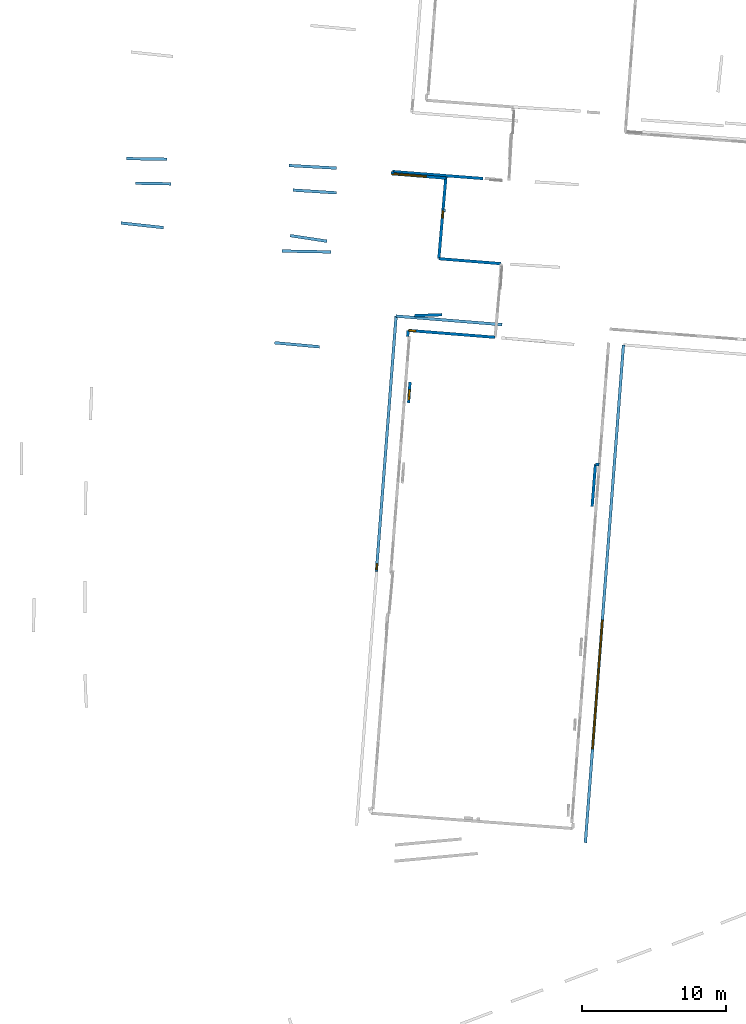
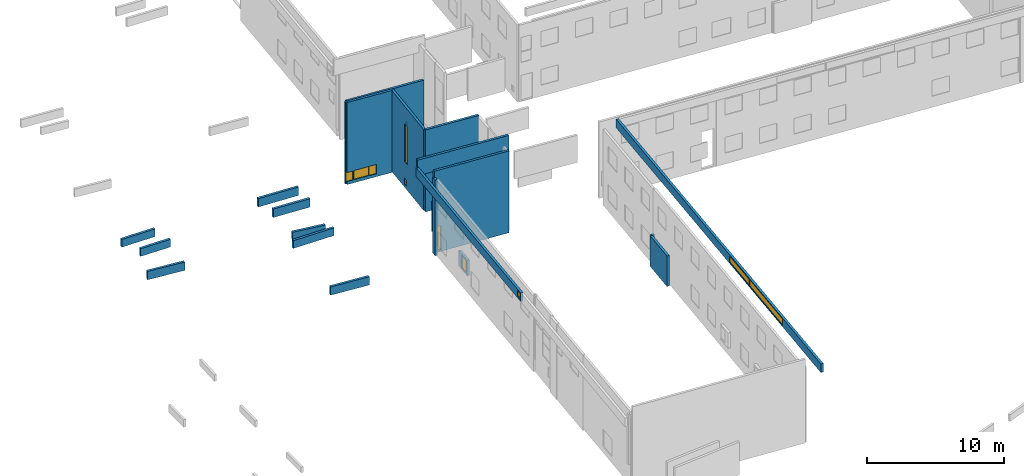
# One storey, part 6 of 27: 23 walls, 10 windows, 10 openings.
"""IFC2X3 building model written with IfcOpenShell, lengths in metres."""

import ifcopenshell
import ifcopenshell.guid

model = None  # the IFC model being written
_history = None  # IfcOwnerHistory: only IFC2X3 demands one
_inside = {}  # id of a spatial element -> (the spatial element, [elements in it])
_under = {}  # id of a project, library or spatial element -> (it, [spatial elements below it])
_declared = {}  # id of a project -> (the project, [libraries it declares])
_typed = {}  # id of a type object -> (the type object, [elements of that type])
_made_of = {}  # id of a material, layer set ... -> (it, [elements and type objects made of it])


def new_model(schema):
    """Start an empty IFC model of exactly this schema.

    Asked for "IFC4X3", IfcOpenShell would pick the latest addendum, in which some entities
    have other attributes; the version numbers below select the first issue.
    IFC2X3 requires an IfcOwnerHistory on every rooted entity: one is made here for all.
    """
    global model, _history
    if schema == "IFC4X3":
        model = ifcopenshell.file(schema_version=(4, 3, 0, 0))
    else:
        model = ifcopenshell.file(schema=schema)
    _inside.clear()
    _under.clear()
    _declared.clear()
    _typed.clear()
    _made_of.clear()
    _history = None
    if model.schema == "IFC2X3":
        org = make("IfcOrganization", Name="unknown")
        user = make(
            "IfcPersonAndOrganization",
            ThePerson=make("IfcPerson", FamilyName="unknown"),
            TheOrganization=org,
        )
        app = make(
            "IfcApplication",
            ApplicationDeveloper=org,
            Version="unknown",
            ApplicationFullName="unknown",
            ApplicationIdentifier="unknown",
        )
        _history = make(
            "IfcOwnerHistory",
            OwningUser=user,
            OwningApplication=app,
            ChangeAction="ADDED",
            CreationDate=0,
        )
    return model


def make(cls, **values):
    """One entity of the class cls with the attributes given. An attribute that is None is left unset."""
    return model.create_entity(
        cls, **{name: value for name, value in values.items() if value is not None}
    )


def entity(cls, *values):
    """Any entity or typed value of the class cls, its attributes in the order of the schema. None: left unset."""
    e = model.create_entity(cls)
    for i, value in enumerate(values):
        if value is not None:
            e[i] = value
    return e


def rooted(cls, **values):
    """An entity with a GlobalId (a new one), such as an element, a storey or a relation."""
    return make(cls, GlobalId=ifcopenshell.guid.new(), OwnerHistory=_history, **values)


def si_unit(unit_type, name, prefix=None):
    """IfcSIUnit, for example si_unit("LENGTHUNIT", "METRE", prefix="MILLI")."""
    return make("IfcSIUnit", UnitType=unit_type, Prefix=prefix, Name=name)


def converted_unit(unit_type, name, factor, base, dimensions=None, offset=None):
    """IfcConversionBasedUnit, such as the inch: factor (a typed value) times the base unit."""
    return make(
        "IfcConversionBasedUnit"
        if offset is None
        else "IfcConversionBasedUnitWithOffset",
        ConversionOffset=offset,
        Dimensions=None
        if dimensions is None
        else entity("IfcDimensionalExponents", *dimensions),
        UnitType=unit_type,
        Name=name,
        ConversionFactor=make(
            "IfcMeasureWithUnit", ValueComponent=factor, UnitComponent=base
        ),
    )


def derived_unit(unit_type, elements):
    """IfcDerivedUnit: a product of units, each with its exponent."""
    return make(
        "IfcDerivedUnit",
        Elements=[
            make("IfcDerivedUnitElement", Unit=unit, Exponent=power)
            for unit, power in elements
        ],
        UnitType=unit_type,
    )


def assignment(units):
    """IfcUnitAssignment: the units of a project."""
    return None if units is None else make("IfcUnitAssignment", Units=units)


def point(xyz):
    """IfcCartesianPoint."""
    return None if xyz is None else make("IfcCartesianPoint", Coordinates=xyz)


def direction(xyz):
    """IfcDirection."""
    return None if xyz is None else make("IfcDirection", DirectionRatios=xyz)


def frame(location, z_axis=None, x_axis=None):
    """IfcAxis2Placement3D, a coordinate frame: its origin and axes. An axis left out is left unset."""
    return make(
        "IfcAxis2Placement3D",
        Location=point(location),
        Axis=direction(z_axis),
        RefDirection=direction(x_axis),
    )


def frame_2d(location, x_axis=None):
    """IfcAxis2Placement2D, a coordinate frame in the plane: its origin and x axis."""
    return make(
        "IfcAxis2Placement2D", Location=point(location), RefDirection=direction(x_axis)
    )


def origin():
    """The frame at (0, 0, 0) with its axes left unset."""
    return frame((0.0, 0.0, 0.0))


def origin_2d_with_axis():
    """The frame at (0, 0) in the plane with the x axis (1, 0) written out."""
    return frame_2d((0.0, 0.0), x_axis=(1.0, 0.0))


def place(relative_to, where):
    """IfcLocalPlacement: puts the frame where relative to a parent placement (None: the world)."""
    return make(
        "IfcLocalPlacement", PlacementRelTo=relative_to, RelativePlacement=where
    )


def context(
    kind, dimensions, precision=None, world=None, true_north=None, identifier=None
):
    """IfcGeometricRepresentationContext, for example the 3D "Model" context."""
    return make(
        "IfcGeometricRepresentationContext",
        ContextIdentifier=identifier,
        ContextType=kind,
        CoordinateSpaceDimension=dimensions,
        Precision=precision,
        WorldCoordinateSystem=world,
        TrueNorth=true_north,
    )


def subcontext(parent, identifier, kind, view, scale=None):
    """IfcGeometricRepresentationSubContext, for example "Body" below "Model"."""
    return make(
        "IfcGeometricRepresentationSubContext",
        ContextIdentifier=identifier,
        ContextType=kind,
        ParentContext=parent,
        TargetScale=scale,
        TargetView=view,
    )


def project(units=None, contexts=None):
    """IfcProject with its units and contexts."""
    return rooted(
        "IfcProject",
        Name="project",
        RepresentationContexts=contexts,
        UnitsInContext=assignment(units),
    )


def spatial(cls, under=None, at=None, **own):
    """A site, building, storey or space (cls), placed at a placement, below another one or the project."""
    s = rooted(cls, ObjectPlacement=at, **own)
    if under is not None:
        _under.setdefault(under.id(), (under, []))[1].append(s)
    return s


def polyline(points):
    """IfcPolyline through the points."""
    return make("IfcPolyline", Points=[point(p) for p in points])


def profile(cls, at=None, kind="AREA", **sizes):
    """A parametric profile (cls). Its sizes go by their IFC names, for example OverallWidth=200.0."""
    return make(cls, ProfileType=kind, Position=at, **sizes)


def rectangle(**sizes):
    """IfcRectangleProfileDef."""
    return profile("IfcRectangleProfileDef", **sizes)


def outline(outer, holes=None, kind="AREA"):
    """IfcArbitraryClosedProfileDef: a profile drawn as a closed curve; with holes, ...WithVoids."""
    if holes is None:
        return make("IfcArbitraryClosedProfileDef", ProfileType=kind, OuterCurve=outer)
    return make(
        "IfcArbitraryProfileDefWithVoids",
        ProfileType=kind,
        OuterCurve=outer,
        InnerCurves=holes,
    )


def extrude(swept, where, along, depth):
    """IfcExtrudedAreaSolid: the profile swept, set in the frame where, extruded along a direction by depth."""
    return make(
        "IfcExtrudedAreaSolid",
        SweptArea=swept,
        Position=where,
        ExtrudedDirection=direction(along),
        Depth=depth,
    )


def shape(context_of_items, identifier, shape_type, items):
    """IfcShapeRepresentation: the items that make up one representation, for example the "Body"."""
    return make(
        "IfcShapeRepresentation",
        ContextOfItems=context_of_items,
        RepresentationIdentifier=identifier,
        RepresentationType=shape_type,
        Items=items,
    )


def source(mapping_origin, context_of_items, identifier, shape_type, items):
    """IfcRepresentationMap: a shape defined once, which mapped items show again and again."""
    return make(
        "IfcRepresentationMap",
        MappingOrigin=mapping_origin,
        MappedRepresentation=shape(context_of_items, identifier, shape_type, items),
    )


def transform(
    local_origin,
    x_axis=None,
    y_axis=None,
    z_axis=None,
    scale=None,
    scale2=None,
    scale3=None,
    uniform=True,
):
    """IfcCartesianTransformationOperator3D, or its non-uniform kind. x_axis, y_axis, z_axis: its Axis1, 2, 3."""
    if uniform:
        return make(
            "IfcCartesianTransformationOperator3D",
            Axis1=direction(x_axis),
            Axis2=direction(y_axis),
            LocalOrigin=point(local_origin),
            Scale=scale,
            Axis3=direction(z_axis),
        )
    return make(
        "IfcCartesianTransformationOperator3DnonUniform",
        Axis1=direction(x_axis),
        Axis2=direction(y_axis),
        LocalOrigin=point(local_origin),
        Scale=scale,
        Axis3=direction(z_axis),
        Scale2=scale2,
        Scale3=scale3,
    )


def mapped(mapping_source, mapping_target):
    """IfcMappedItem: shows the shape of a source again, moved by a transform."""
    return make(
        "IfcMappedItem", MappingSource=mapping_source, MappingTarget=mapping_target
    )


def material(Name=None, Category=None):
    """IfcMaterial."""
    return make("IfcMaterial", Name=Name, Category=Category)


def layer(
    of_material, thickness, ventilated=None, Name=None, Category=None, Priority=None
):
    """IfcMaterialLayer: one layer of a wall or slab, of a material (None: an air gap)."""
    return make(
        "IfcMaterialLayer",
        Material=of_material,
        LayerThickness=thickness,
        IsVentilated=ventilated,
        Name=Name,
        Category=Category,
        Priority=Priority,
    )


def layer_set(layers, Name=None):
    """IfcMaterialLayerSet."""
    return make("IfcMaterialLayerSet", MaterialLayers=layers, LayerSetName=Name)


def layer_usage(for_layer_set, set_direction, sense, offset, extent=None):
    """IfcMaterialLayerSetUsage: how a layer set lies in its element."""
    return make(
        "IfcMaterialLayerSetUsage",
        ForLayerSet=for_layer_set,
        LayerSetDirection=set_direction,
        DirectionSense=sense,
        OffsetFromReferenceLine=offset,
        ReferenceExtent=extent,
    )


def made_of(thing, what):
    """Note that an element or type object is made of a material, layer set ...; save() writes the relation."""
    if what is not None:
        _made_of.setdefault(what.id(), (what, []))[1].append(thing)
    return thing


def type_object(cls, material=None, **own):
    """A type object (cls), such as IfcWallType, which elements share."""
    return made_of(rooted(cls, **own), material)


def type_shapes(of_type, sources):
    """Give a type object the sources (RepresentationMaps) that its elements show as mapped items."""
    of_type.RepresentationMaps = sources


def element(
    cls,
    number,
    at=None,
    inside=None,
    cuts=None,
    type_object=None,
    material=None,
    context=None,
    identifier="Body",
    shape_type=None,
    held_by="IfcProductDefinitionShape",
    body=None,
    shapes=None,
    **own,
):
    """One element of the class cls, such as IfcWall. Its Tag is "e" and its number.

    at: its placement. inside: the storey or other place that contains it. cuts: it is an
    opening in that element (IfcRelVoidsElement). A single representation is given by context,
    identifier, shape_type and body (its items); several are given by shapes. held_by: the class
    of the entity that holds the representations. save() writes the other relations.
    """
    e = rooted(cls, Tag="e%d" % number, ObjectPlacement=at, **own)
    if body is not None:
        shapes = [shape(context, identifier, shape_type, body)]
    if shapes is not None:
        e.Representation = make(held_by, Representations=shapes)
    if inside is not None:
        _inside.setdefault(inside.id(), (inside, []))[1].append(e)
    if cuts is not None:
        rooted(
            "IfcRelVoidsElement", RelatingBuildingElement=cuts, RelatedOpeningElement=e
        )
    if type_object is not None:
        _typed.setdefault(type_object.id(), (type_object, []))[1].append(e)
    return made_of(e, material)


def fill(opening, filler):
    """IfcRelFillsElement: the door or window that sits in an opening."""
    return rooted(
        "IfcRelFillsElement",
        RelatingOpeningElement=opening,
        RelatedBuildingElement=filler,
    )


def aggregate(whole, parts):
    """IfcRelAggregates: a whole, such as a stair, and the parts it consists of."""
    return rooted("IfcRelAggregates", RelatingObject=whole, RelatedObjects=parts)


def save(model, path):
    """Write the relations noted so far, then the file.

    IfcRelAggregates (storeys below a building ...), IfcRelContainedInSpatialStructure (elements
    in a storey), IfcRelDefinesByType, IfcRelAssociatesMaterial and IfcRelDeclares: one each for
    every whole, place, type object, material and project.
    """
    for whole, parts in _under.values():
        aggregate(whole, parts)
    for where, things in _inside.values():
        rooted(
            "IfcRelContainedInSpatialStructure",
            RelatedElements=things,
            RelatingStructure=where,
        )
    for kind, things in _typed.values():
        rooted("IfcRelDefinesByType", RelatedObjects=things, RelatingType=kind)
    for what, things in _made_of.values():
        rooted("IfcRelAssociatesMaterial", RelatedObjects=things, RelatingMaterial=what)
    for by, libraries in _declared.values():
        rooted("IfcRelDeclares", RelatingContext=by, RelatedDefinitions=libraries)
    model.write(path)


model = new_model("IFC2X3")

# Units and contexts
model_context = context("Model", 3, precision=1e-05, world=origin(), true_north=direction((0.0, 1.0)))
body_context = subcontext(model_context, "Body", "Model", "MODEL_VIEW")
ifc_project = project(units=[si_unit("LENGTHUNIT", "METRE"), si_unit("AREAUNIT", "SQUARE_METRE"), si_unit("VOLUMEUNIT", "CUBIC_METRE"), converted_unit("PLANEANGLEUNIT", "DEGREE", entity("IfcRatioMeasure", 0.0174532925199433), si_unit("PLANEANGLEUNIT", "RADIAN"), dimensions=[0, 0, 0, 0, 0, 0, 0]), si_unit("MASSUNIT", "GRAM", prefix="KILO"), derived_unit("MASSDENSITYUNIT", [(si_unit("MASSUNIT", "GRAM", prefix="KILO"), 1), (si_unit("LENGTHUNIT", "METRE"), -3)]), derived_unit("MOMENTOFINERTIAUNIT", [(si_unit("LENGTHUNIT", "METRE"), 4)]), si_unit("TIMEUNIT", "SECOND"), si_unit("FREQUENCYUNIT", "HERTZ"), si_unit("THERMODYNAMICTEMPERATUREUNIT", "DEGREE_CELSIUS"), derived_unit("THERMALTRANSMITTANCEUNIT", [(si_unit("MASSUNIT", "GRAM", prefix="KILO"), 1), (si_unit("THERMODYNAMICTEMPERATUREUNIT", "KELVIN"), -1), (si_unit("TIMEUNIT", "SECOND"), -3)]), derived_unit("VOLUMETRICFLOWRATEUNIT", [(si_unit("LENGTHUNIT", "METRE"), 3), (si_unit("TIMEUNIT", "SECOND"), -1)]), si_unit("ELECTRICCURRENTUNIT", "AMPERE"), si_unit("ELECTRICVOLTAGEUNIT", "VOLT"), si_unit("POWERUNIT", "WATT"), si_unit("FORCEUNIT", "NEWTON", prefix="KILO"), si_unit("ILLUMINANCEUNIT", "LUX"), si_unit("LUMINOUSFLUXUNIT", "LUMEN"), si_unit("LUMINOUSINTENSITYUNIT", "CANDELA"), derived_unit("USERDEFINED", [(si_unit("MASSUNIT", "GRAM", prefix="KILO"), -1), (si_unit("LENGTHUNIT", "METRE"), -2), (si_unit("TIMEUNIT", "SECOND"), 3), (si_unit("LUMINOUSFLUXUNIT", "LUMEN"), 1)]), derived_unit("LINEARVELOCITYUNIT", [(si_unit("LENGTHUNIT", "METRE"), 1), (si_unit("TIMEUNIT", "SECOND"), -1)]), si_unit("PRESSUREUNIT", "PASCAL"), derived_unit("USERDEFINED", [(si_unit("LENGTHUNIT", "METRE"), -2), (si_unit("MASSUNIT", "GRAM", prefix="KILO"), 1), (si_unit("TIMEUNIT", "SECOND"), -2)]), derived_unit("LINEARFORCEUNIT", [(si_unit("MASSUNIT", "GRAM", prefix="KILO"), 1), (si_unit("LENGTHUNIT", "METRE"), 1), (si_unit("TIMEUNIT", "SECOND"), -2), (si_unit("LENGTHUNIT", "METRE"), -1)]), derived_unit("PLANARFORCEUNIT", [(si_unit("MASSUNIT", "GRAM", prefix="KILO"), 1), (si_unit("LENGTHUNIT", "METRE"), 1), (si_unit("TIMEUNIT", "SECOND"), -2), (si_unit("LENGTHUNIT", "METRE"), -2)])], contexts=[model_context])

# Site, building, storey
placement_1 = place(None, origin())
site = spatial("IfcSite", under=ifc_project, at=placement_1, CompositionType="ELEMENT")
building = spatial("IfcBuilding", under=site, at=placement_1, CompositionType="ELEMENT")
storey_placement = place(placement_1, frame((0.0, 0.0, -61.043098449707)))
storey = spatial("IfcBuildingStorey", under=building, at=storey_placement, Name="level_-61.043098", CompositionType="ELEMENT", Elevation=-61.043098449707)

# Wall, openings, windows
ifc_material_1 = material(Name="Default wall")
ifc_layer = layer(ifc_material_1, 0.2)
ifc_layer_set = layer_set([ifc_layer], Name="wall_thickness_0.2000")
ifc_layer_usage = layer_usage(ifc_layer_set, "AXIS2", "POSITIVE", -0.1)
wall_type = type_object("IfcWallType", Name="wall_thickness_0.2000", PredefinedType="STANDARD", material=ifc_layer_set)
placement_2 = place(placement_1, frame((0.0, 0.0, -60.9578857421875)))
wall_1_placement = place(placement_2, frame((-82.9743263470563, -2.62304105643259, 0.0), z_axis=(0.0, 0.0, 1.0), x_axis=(-0.086478547325149, -0.996253713093473, 0.0)))
wall_1 = element("IfcWallStandardCase", 1, at=wall_1_placement, inside=storey, type_object=wall_type, material=ifc_layer_usage, Name="Wall:180", ObjectType="Wall", context=body_context, shape_type="SweptSolid", body=[
    extrude(outline(polyline([(5.77842827457499, -0.1), (5.77842827457499, 0.1), (0.0, 0.1), (0.0, -0.1), (5.77842827457499, -0.1)])), origin(), (0.0, 0.0, 1.0), 7.24139404296875),
])
opening_1_placement = place(wall_1_placement, frame((2.4950191979446, -0.1, 2.31532287597656)))
opening_1 = element("IfcOpeningElement", 2, at=opening_1_placement, cuts=wall_1, Name="Opening : 450 x 3360 : 12", ObjectType="Opening", context=body_context, shape_type="SweptSolid", body=[
    extrude(rectangle(XDim=0.45, YDim=3.36, at=frame_2d((1.68, 0.225), x_axis=(0.0, 1.0))), frame((0.0, 0.0, 0.0), z_axis=(0.0, 1.0, 0.0), x_axis=(0.0, 0.0, 1.0)), (0.0, 0.0, 1.0), 0.2),
])
opening_2_placement = place(wall_1_placement, frame((2.45501823867597, -0.1, 0.270320892333984)))
opening_2 = element("IfcOpeningElement", 3, at=opening_2_placement, cuts=wall_1, Name="Opening : 325 x 555 : 13", ObjectType="Opening", context=body_context, shape_type="SweptSolid", body=[
    extrude(rectangle(XDim=0.325, YDim=0.555, at=frame_2d((0.2775, 0.1625), x_axis=(0.0, 1.0))), frame((0.0, 0.0, 0.0), z_axis=(0.0, 1.0, 0.0), x_axis=(0.0, 0.0, 1.0)), (0.0, 0.0, 1.0), 0.2),
])
ifc_material_2 = material(Name="Window Default")
window_style_1 = type_object("IfcWindowStyle", Name="Window : 450 x 3360mm", ConstructionType="NOTDEFINED", OperationType="NOTDEFINED", ParameterTakesPrecedence=False, Sizeable=False, material=ifc_material_2)
shared_shape_1 = source(origin(), body_context, "Body", "SweptSolid", [
    extrude(rectangle(XDim=0.1, YDim=0.45, at=origin_2d_with_axis()), frame((0.225, 0.1, 0.0), z_axis=(0.0, 0.0, 1.0), x_axis=(0.0, 1.0, 0.0)), (0.0, 0.0, 1.0), 3.36),
])
type_shapes(window_style_1, [shared_shape_1])
window_1_placement = place(opening_1_placement, origin())
window_1 = element("IfcWindow", 4, at=window_1_placement, inside=storey, type_object=window_style_1, Name="Window : 450 x 3360mm : 10", ObjectType="Window : 450 x 3360mm", OverallHeight=3.36, OverallWidth=0.45, context=body_context, shape_type="MappedRepresentation", body=[
    mapped(shared_shape_1, transform((0.0, 0.0, 0.0), scale=1.0)),
])
fill(opening_1, window_1)
window_style_2 = type_object("IfcWindowStyle", Name="Window : 325 x 555mm", ConstructionType="NOTDEFINED", OperationType="NOTDEFINED", ParameterTakesPrecedence=False, Sizeable=False, material=ifc_material_2)
shared_shape_2 = source(origin(), body_context, "Body", "SweptSolid", [
    extrude(rectangle(XDim=0.1, YDim=0.325, at=origin_2d_with_axis()), frame((0.1625, 0.1, 0.0), z_axis=(0.0, 0.0, 1.0), x_axis=(0.0, 1.0, 0.0)), (0.0, 0.0, 1.0), 0.555),
])
type_shapes(window_style_2, [shared_shape_2])
window_2_placement = place(opening_2_placement, origin())
window_2 = element("IfcWindow", 5, at=window_2_placement, inside=storey, type_object=window_style_2, Name="Window : 325 x 555mm : 11", ObjectType="Window : 325 x 555mm", OverallHeight=0.555, OverallWidth=0.325, context=body_context, shape_type="MappedRepresentation", body=[
    mapped(shared_shape_2, transform((0.0, 0.0, 0.0), scale=1.0)),
])
fill(opening_2, window_2)

# Walls
wall_2_placement = place(storey_placement, frame((-79.1526717475853, -8.72578700694253, 0.0), z_axis=(0.0, 0.0, 1.0), x_axis=(-0.99681056863633, 0.079804074174927, 0.0)))
element("IfcWallStandardCase", 6, at=wall_2_placement, inside=storey, type_object=wall_type, material=ifc_layer_usage, Name="Wall:231", ObjectType="Wall", context=body_context, shape_type="SweptSolid", body=[
    extrude(outline(polyline([(4.33518450046386, -0.1), (4.33518450046386, 0.1), (0.0, 0.1), (0.0, -0.1), (4.33518450046386, -0.1)])), origin(), (0.0, 0.0, 1.0), 7.32660675048828),
])
placement_3 = place(placement_1, frame((0.0, 0.0, -60.9578857421875)))
wall_3_placement = place(placement_3, frame((-94.8565916781149, -14.2122311641715, 0.0), z_axis=(0.0, 0.0, 1.0), x_axis=(0.995926807111139, -0.0901653751581592, 0.0)))
element("IfcWallStandardCase", 7, at=wall_3_placement, inside=storey, type_object=wall_type, material=ifc_layer_usage, Name="Wall:256", ObjectType="Wall", context=body_context, shape_type="SweptSolid", body=[
    extrude(outline(polyline([(3.1150058296527, -0.1), (3.1150058296527, 0.1), (0.0, 0.1), (0.0, -0.1), (3.1150058296527, -0.1)])), origin(), (0.0, 0.0, 1.0), 0.739894866943359),
])

# Wall, opening, window
placement_4 = place(placement_1, frame((0.0, 0.0, -59.9867630004883)))
wall_4_placement = place(placement_4, frame((-85.4728665028162, -16.9459447821099, 0.0), z_axis=(0.0, 0.0, 1.0), x_axis=(-0.0695705399147485, -0.997577034607338, 0.0)))
wall_4 = element("IfcWallStandardCase", 8, at=wall_4_placement, inside=storey, type_object=wall_type, material=ifc_layer_usage, Name="Wall:398", ObjectType="Wall", context=body_context, shape_type="SweptSolid", body=[
    extrude(outline(polyline([(1.43462648673011, -0.1), (1.43462648673011, 0.1), (0.0, 0.1), (0.0, -0.1), (1.43462648673011, -0.1)])), origin(), (0.0, 0.0, 1.0), 1.37465286254883),
])
opening_3_placement = place(wall_4_placement, frame((0.525001199247434, -0.1, 0.154670715332031)))
opening_3 = element("IfcOpeningElement", 9, at=opening_3_placement, cuts=wall_4, Name="Opening : 700 x 1080 : 33", ObjectType="Opening", context=body_context, shape_type="SweptSolid", body=[
    extrude(rectangle(XDim=0.7, YDim=1.08, at=frame_2d((0.54, 0.35), x_axis=(0.0, 1.0))), frame((0.0, 0.0, 0.0), z_axis=(0.0, 1.0, 0.0), x_axis=(0.0, 0.0, 1.0)), (0.0, 0.0, 1.0), 0.2),
])
window_style_3 = type_object("IfcWindowStyle", Name="Window : 700 x 1080mm", ConstructionType="NOTDEFINED", OperationType="NOTDEFINED", ParameterTakesPrecedence=False, Sizeable=False, material=ifc_material_2)
shared_shape_3 = source(origin(), body_context, "Body", "SweptSolid", [
    extrude(rectangle(XDim=0.1, YDim=0.7, at=origin_2d_with_axis()), frame((0.35, 0.1, 0.0), z_axis=(0.0, 0.0, 1.0), x_axis=(0.0, 1.0, 0.0)), (0.0, 0.0, 1.0), 1.08),
])
type_shapes(window_style_3, [shared_shape_3])
window_3_placement = place(opening_3_placement, origin())
window_3 = element("IfcWindow", 10, at=window_3_placement, inside=storey, type_object=window_style_3, Name="Window : 700 x 1080mm : 30", ObjectType="Window : 700 x 1080mm", OverallHeight=1.08, OverallWidth=0.7, context=body_context, shape_type="MappedRepresentation", body=[
    mapped(shared_shape_3, transform((0.0, 0.0, 0.0), scale=1.0)),
])
fill(opening_3, window_3)

# Wall
wall_5_placement = place(storey_placement, frame((-72.3485135393419, -22.6579491111474, 0.0), z_axis=(0.0, 0.0, 1.0), x_axis=(-0.99800429123349, 0.0631461374870972, 0.0)))
element("IfcWallStandardCase", 11, at=wall_5_placement, inside=storey, type_object=wall_type, material=ifc_layer_usage, Name="Wall:435", ObjectType="Wall", context=body_context, shape_type="SweptSolid", body=[
    extrude(outline(polyline([(0.263511120946333, -0.1), (0.263511120946333, 0.1), (0.0, 0.1), (0.0, -0.1), (0.263511120946333, -0.1)])), origin(), (0.0, 0.0, 1.0), 2.72571182250977),
])

# Wall, opening, window
placement_5 = place(placement_1, frame((0.0, 0.0, -60.9578857421875)))
wall_6_placement = place(placement_5, frame((-79.5663018405529, -13.8312961996762, 0.0), z_axis=(0.0, 0.0, 1.0), x_axis=(-0.996887629814218, 0.078835610756751, 0.0)))
wall_6 = element("IfcWallStandardCase", 12, at=wall_6_placement, inside=storey, type_object=wall_type, material=ifc_layer_usage, Name="Wall:629", ObjectType="Wall", context=body_context, shape_type="SweptSolid", body=[
    extrude(outline(polyline([(6.04767697964186, -0.1), (6.04767697964186, 0.1), (0.0, 0.1), (0.0, -0.1), (6.04767697964186, -0.1)])), origin(), (0.0, 0.0, 1.0), 7.30948257446289),
])
opening_4_placement = place(wall_6_placement, frame((5.52663087314132, -0.1, 0.169719696044922)))
opening_4 = element("IfcOpeningElement", 13, at=opening_4_placement, cuts=wall_6, Name="Opening : 480 x 2130 : 48", ObjectType="Opening", context=body_context, shape_type="SweptSolid", body=[
    extrude(rectangle(XDim=0.48, YDim=2.13, at=frame_2d((1.065, 0.24), x_axis=(0.0, 1.0))), frame((0.0, 0.0, 0.0), z_axis=(0.0, 1.0, 0.0), x_axis=(0.0, 0.0, 1.0)), (0.0, 0.0, 1.0), 0.2),
])
window_style_4 = type_object("IfcWindowStyle", Name="Window : 480 x 2130mm", ConstructionType="NOTDEFINED", OperationType="NOTDEFINED", ParameterTakesPrecedence=False, Sizeable=False, material=ifc_material_2)
shared_shape_4 = source(origin(), body_context, "Body", "SweptSolid", [
    extrude(rectangle(XDim=0.1, YDim=0.48, at=origin_2d_with_axis()), frame((0.24, 0.1, 0.0), z_axis=(0.0, 0.0, 1.0), x_axis=(0.0, 1.0, 0.0)), (0.0, 0.0, 1.0), 2.13),
])
type_shapes(window_style_4, [shared_shape_4])
window_4_placement = place(opening_4_placement, origin())
window_4 = element("IfcWindow", 14, at=window_4_placement, inside=storey, type_object=window_style_4, Name="Window : 480 x 2130mm : 41", ObjectType="Window : 480 x 2130mm", OverallHeight=2.13, OverallWidth=0.48, context=body_context, shape_type="MappedRepresentation", body=[
    mapped(shared_shape_4, transform((0.0, 0.0, 0.0), scale=1.0)),
])
fill(opening_4, window_4)

# Walls
placement_6 = place(placement_1, frame((0.0, 0.0, -58.6692237854004)))
wall_7_placement = place(placement_6, frame((-83.0006708136844, -5.03142669705122, 0.0), z_axis=(0.0, 0.0, 1.0), x_axis=(-0.995771170624382, 0.0918682521513729, 0.0)))
element("IfcWallStandardCase", 15, at=wall_7_placement, inside=storey, type_object=wall_type, material=ifc_layer_usage, Name="Wall:679", ObjectType="Wall", context=body_context, shape_type="SweptSolid", body=[
    extrude(outline(polyline([(0.182028924536731, -0.1), (0.182028924536731, 0.1), (0.0, 0.1), (0.0, -0.1), (0.182028924536731, -0.1)])), origin(), (0.0, 0.0, 1.0), 3.40566635131836),
])
placement_7 = place(placement_1, frame((0.0, 0.0, -60.8194160461426)))
wall_8_placement = place(placement_7, frame((-104.525196029959, -3.1443835598275, 0.0), z_axis=(0.0, 0.0, 1.0), x_axis=(0.999835830971327, -0.0181193572147802, 0.0)))
element("IfcWallStandardCase", 16, at=wall_8_placement, inside=storey, type_object=wall_type, material=ifc_layer_usage, Name="Wall:771", ObjectType="Wall", context=body_context, shape_type="SweptSolid", body=[
    extrude(outline(polyline([(2.48499658252208, -0.1), (2.48499658252208, 0.1), (0.0, 0.1), (0.0, -0.1), (2.48499658252208, -0.1)])), origin(), (0.0, 0.0, 1.0), 0.685939788818359),
])
placement_8 = place(placement_1, frame((0.0, 0.0, -60.8194160461426)))
wall_9_placement = place(placement_8, frame((-105.130464734849, -1.43733439239155, 0.0), z_axis=(0.0, 0.0, 1.0), x_axis=(0.999868849155916, -0.0161951995240483, 0.0)))
element("IfcWallStandardCase", 17, at=wall_9_placement, inside=storey, type_object=wall_type, material=ifc_layer_usage, Name="Wall:960", ObjectType="Wall", context=body_context, shape_type="SweptSolid", body=[
    extrude(outline(polyline([(2.7899929851303, -0.1), (2.7899929851303, 0.1), (0.0, 0.1), (0.0, -0.1), (2.7899929851303, -0.1)])), origin(), (0.0, 0.0, 1.0), 0.685939788818359),
])
placement_9 = place(placement_1, frame((0.0, 0.0, -60.8847198486328)))
wall_10_placement = place(placement_9, frame((-93.5873377438679, -3.62334279420738, 0.0), z_axis=(0.0, 0.0, 1.0), x_axis=(0.998024522752575, -0.0628255679202001, 0.0)))
element("IfcWallStandardCase", 18, at=wall_10_placement, inside=storey, type_object=wall_type, material=ifc_layer_usage, Name="Wall:1003", ObjectType="Wall", context=body_context, shape_type="SweptSolid", body=[
    extrude(outline(polyline([(3.00999738985456, -0.1), (3.00999738985456, 0.1), (0.0, 0.1), (0.0, -0.1), (3.00999738985456, -0.1)])), origin(), (0.0, 0.0, 1.0), 0.751243591308594),
])
placement_10 = place(placement_1, frame((0.0, 0.0, -60.9578857421875)))
wall_11_placement = place(placement_10, frame((-80.406335817382, -2.82274813786517, 0.0), z_axis=(0.0, 0.0, 1.0), x_axis=(-0.996989741547515, 0.0775335749789646, 0.0)))
element("IfcWallStandardCase", 19, at=wall_11_placement, inside=storey, type_object=wall_type, material=ifc_layer_usage, Name="Wall:1010", ObjectType="Wall", context=body_context, shape_type="SweptSolid", body=[
    extrude(outline(polyline([(6.29527945872874, -0.1), (6.29527945872874, 0.1), (0.0, 0.1), (0.0, -0.1), (6.29527945872874, -0.1)])), origin(), (0.0, 0.0, 1.0), 7.24139404296875),
])
placement_11 = place(placement_1, frame((0.0, 0.0, -60.9578857421875)))
wall_12_placement = place(placement_11, frame((-85.638898771457, -13.7857217097748, 0.0), z_axis=(0.0, 0.0, 1.0), x_axis=(0.10093648646563, 0.994892871469071, 0.0)))
element("IfcWallStandardCase", 20, at=wall_12_placement, inside=storey, type_object=wall_type, material=ifc_layer_usage, Name="Wall:1156", ObjectType="Wall", context=body_context, shape_type="SweptSolid", body=[
    extrude(outline(polyline([(0.433410650340835, -0.1), (0.433410650340835, 0.1), (0.0, 0.1), (0.0, -0.1), (0.433410650340835, -0.1)])), origin(), (0.0, 0.0, 1.0), 6.74871063232422),
])

# Wall, openings, windows
wall_13_placement = place(storey_placement, frame((-86.6974794785527, -2.49534803383844, 0.0), z_axis=(0.0, 0.0, 1.0), x_axis=(0.996767904124647, -0.0803352058997679, 0.0)))
wall_13 = element("IfcWallStandardCase", 21, at=wall_13_placement, inside=storey, type_object=wall_type, material=ifc_layer_usage, Name="Wall:1244", ObjectType="Wall", context=body_context, shape_type="SweptSolid", body=[
    extrude(outline(polyline([(3.72031451329108, -0.1), (3.72031451329108, 0.1), (0.0, 0.1), (0.0, -0.1), (3.72031451329108, -0.1)])), origin(), (0.0, 0.0, 1.0), 7.32660675048828),
])
opening_5_placement = place(wall_13_placement, frame((0.564209127632863, -0.1, 0.286457061767578)))
opening_5 = element("IfcOpeningElement", 22, at=opening_5_placement, cuts=wall_13, Name="Opening : 1200 x 805 : 169", ObjectType="Opening", context=body_context, shape_type="SweptSolid", body=[
    extrude(rectangle(XDim=1.2, YDim=0.805, at=frame_2d((0.4025, 0.6), x_axis=(0.0, 1.0))), frame((0.0, 0.0, 0.0), z_axis=(0.0, 1.0, 0.0), x_axis=(0.0, 0.0, 1.0)), (0.0, 0.0, 1.0), 0.2),
])
opening_6_placement = place(wall_13_placement, frame((1.78420910195725, -0.1, 0.266456604003906)))
opening_6 = element("IfcOpeningElement", 23, at=opening_6_placement, cuts=wall_13, Name="Opening : 575 x 830 : 170", ObjectType="Opening", context=body_context, shape_type="SweptSolid", body=[
    extrude(rectangle(XDim=0.575, YDim=0.83, at=frame_2d((0.415, 0.2875), x_axis=(0.0, 1.0))), frame((0.0, 0.0, 0.0), z_axis=(0.0, 1.0, 0.0), x_axis=(0.0, 0.0, 1.0)), (0.0, 0.0, 1.0), 0.2),
])
opening_7_placement = place(wall_13_placement, frame((-0.075791232901354, -0.1, 0.281455993652344)))
opening_7 = element("IfcOpeningElement", 24, at=opening_7_placement, cuts=wall_13, Name="Opening : 545 x 790 : 171", ObjectType="Opening", context=body_context, shape_type="SweptSolid", body=[
    extrude(rectangle(XDim=0.545, YDim=0.79, at=frame_2d((0.395, 0.2725), x_axis=(0.0, 1.0))), frame((0.0, 0.0, 0.0), z_axis=(0.0, 1.0, 0.0), x_axis=(0.0, 0.0, 1.0)), (0.0, 0.0, 1.0), 0.2),
])
window_style_5 = type_object("IfcWindowStyle", Name="Window : 1200 x 805mm", ConstructionType="NOTDEFINED", OperationType="NOTDEFINED", ParameterTakesPrecedence=False, Sizeable=False, material=ifc_material_2)
shared_shape_5 = source(origin(), body_context, "Body", "SweptSolid", [
    extrude(rectangle(XDim=0.1, YDim=1.2, at=origin_2d_with_axis()), frame((0.6, 0.1, 0.0), z_axis=(0.0, 0.0, 1.0), x_axis=(0.0, 1.0, 0.0)), (0.0, 0.0, 1.0), 0.805),
])
type_shapes(window_style_5, [shared_shape_5])
window_5_placement = place(opening_5_placement, origin())
window_5 = element("IfcWindow", 25, at=window_5_placement, inside=storey, type_object=window_style_5, Name="Window : 1200 x 805mm : 154", ObjectType="Window : 1200 x 805mm", OverallHeight=0.805, OverallWidth=1.2, context=body_context, shape_type="MappedRepresentation", body=[
    mapped(shared_shape_5, transform((0.0, 0.0, 0.0), scale=1.0)),
])
fill(opening_5, window_5)
window_style_6 = type_object("IfcWindowStyle", Name="Window : 575 x 830mm", ConstructionType="NOTDEFINED", OperationType="NOTDEFINED", ParameterTakesPrecedence=False, Sizeable=False, material=ifc_material_2)
shared_shape_6 = source(origin(), body_context, "Body", "SweptSolid", [
    extrude(rectangle(XDim=0.1, YDim=0.575, at=origin_2d_with_axis()), frame((0.2875, 0.1, 0.0), z_axis=(0.0, 0.0, 1.0), x_axis=(0.0, 1.0, 0.0)), (0.0, 0.0, 1.0), 0.83),
])
type_shapes(window_style_6, [shared_shape_6])
window_6_placement = place(opening_6_placement, origin())
window_6 = element("IfcWindow", 26, at=window_6_placement, inside=storey, type_object=window_style_6, Name="Window : 575 x 830mm : 155", ObjectType="Window : 575 x 830mm", OverallHeight=0.83, OverallWidth=0.575, context=body_context, shape_type="MappedRepresentation", body=[
    mapped(shared_shape_6, transform((0.0, 0.0, 0.0), scale=1.0)),
])
fill(opening_6, window_6)
window_style_7 = type_object("IfcWindowStyle", Name="Window : 545 x 790mm", ConstructionType="NOTDEFINED", OperationType="NOTDEFINED", ParameterTakesPrecedence=False, Sizeable=False, material=ifc_material_2)
shared_shape_7 = source(origin(), body_context, "Body", "SweptSolid", [
    extrude(rectangle(XDim=0.1, YDim=0.545, at=origin_2d_with_axis()), frame((0.2725, 0.1, 0.0), z_axis=(0.0, 0.0, 1.0), x_axis=(0.0, 1.0, 0.0)), (0.0, 0.0, 1.0), 0.79),
])
type_shapes(window_style_7, [shared_shape_7])
window_7_placement = place(opening_7_placement, origin())
window_7 = element("IfcWindow", 27, at=window_7_placement, inside=storey, type_object=window_style_7, Name="Window : 545 x 790mm : 156", ObjectType="Window : 545 x 790mm", OverallHeight=0.79, OverallWidth=0.545, context=body_context, shape_type="MappedRepresentation", body=[
    mapped(shared_shape_7, transform((0.0, 0.0, 0.0), scale=1.0)),
])
fill(opening_7, window_7)

# Wall
placement_12 = place(placement_1, frame((0.0, 0.0, -60.8847198486328)))
wall_14_placement = place(placement_12, frame((-93.7786159255877, -6.78073835561927, 0.0), z_axis=(0.0, 0.0, 1.0), x_axis=(0.988655110072893, -0.150203439796685, 0.0)))
element("IfcWallStandardCase", 28, at=wall_14_placement, inside=storey, type_object=wall_type, material=ifc_layer_usage, Name="Wall:1254", ObjectType="Wall", context=body_context, shape_type="SweptSolid", body=[
    extrude(outline(polyline([(2.58499821207226, -0.1), (2.58499821207226, 0.1), (0.0, 0.1), (0.0, -0.1), (2.58499821207226, -0.1)])), origin(), (0.0, 0.0, 1.0), 0.666728973388672),
])

# Wall, opening, window
placement_13 = place(placement_1, frame((0.0, 0.0, -54.4207000732422)))
wall_15_placement = place(placement_13, frame((-87.8035000195072, -30.0745020636195, 0.0), z_axis=(0.0, 0.0, 1.0), x_axis=(0.0769315700220849, 0.997036375231083, 0.0)))
wall_15 = element("IfcWallStandardCase", 29, at=wall_15_placement, inside=storey, type_object=wall_type, material=ifc_layer_usage, Name="Wall:1329", ObjectType="Wall", context=body_context, shape_type="SweptSolid", body=[
    extrude(outline(polyline([(17.7631449672362, -0.1), (17.7631449672362, 0.1), (0.0, 0.1), (0.0, -0.1), (17.7631449672362, -0.1)])), origin(), (0.0, 0.0, 1.0), 0.772296905517578),
])
opening_8_placement = place(wall_15_placement, frame((0.134999548272284, -0.1, 0.157157897949219)))
opening_8 = element("IfcOpeningElement", 30, at=opening_8_placement, cuts=wall_15, Name="Opening : 415 x 510 : 200", ObjectType="Opening", context=body_context, shape_type="SweptSolid", body=[
    extrude(rectangle(XDim=0.415, YDim=0.51, at=frame_2d((0.255, 0.2075), x_axis=(0.0, 1.0))), frame((0.0, 0.0, 0.0), z_axis=(0.0, 1.0, 0.0), x_axis=(0.0, 0.0, 1.0)), (0.0, 0.0, 1.0), 0.2),
])
window_style_8 = type_object("IfcWindowStyle", Name="Window : 415 x 510mm", ConstructionType="NOTDEFINED", OperationType="NOTDEFINED", ParameterTakesPrecedence=False, Sizeable=False, material=ifc_material_2)
shared_shape_8 = source(origin(), body_context, "Body", "SweptSolid", [
    extrude(rectangle(XDim=0.1, YDim=0.415, at=origin_2d_with_axis()), frame((0.2075, 0.1, 0.0), z_axis=(0.0, 0.0, 1.0), x_axis=(0.0, 1.0, 0.0)), (0.0, 0.0, 1.0), 0.51),
])
type_shapes(window_style_8, [shared_shape_8])
window_8_placement = place(opening_8_placement, origin())
window_8 = element("IfcWindow", 31, at=window_8_placement, inside=storey, type_object=window_style_8, Name="Window : 415 x 510mm : 183", ObjectType="Window : 415 x 510mm", OverallHeight=0.51, OverallWidth=0.415, context=body_context, shape_type="MappedRepresentation", body=[
    mapped(shared_shape_8, transform((0.0, 0.0, 0.0), scale=1.0)),
])
fill(opening_8, window_8)

# Walls
wall_16_placement = place(storey_placement, frame((-72.6114880160132, -22.6413130644445, 0.0), z_axis=(0.0, 0.0, 1.0), x_axis=(-0.0783021999633183, -0.996929669275072, 0.0)))
element("IfcWallStandardCase", 32, at=wall_16_placement, inside=storey, type_object=wall_type, material=ifc_layer_usage, Name="Wall:1336", ObjectType="Wall", context=body_context, shape_type="SweptSolid", body=[
    extrude(outline(polyline([(2.92792930174968, -0.1), (2.92792930174968, 0.1), (0.0, 0.1), (0.0, -0.1), (2.92792930174968, -0.1)])), origin(), (0.0, 0.0, 1.0), 2.72571182250977),
])
placement_14 = place(placement_1, frame((0.0, 0.0, -60.8847198486328)))
wall_17_placement = place(placement_14, frame((-93.8727170152929, -1.91928278020951, 0.0), z_axis=(0.0, 0.0, 1.0), x_axis=(0.99855556216979, -0.053728849417933, 0.0)))
element("IfcWallStandardCase", 33, at=wall_17_placement, inside=storey, type_object=wall_type, material=ifc_layer_usage, Name="Wall:1425", ObjectType="Wall", context=body_context, shape_type="SweptSolid", body=[
    extrude(outline(polyline([(3.31544263729263, -0.1), (3.31544263729263, 0.1), (0.0, 0.1), (0.0, -0.1), (3.31544263729263, -0.1)])), origin(), (0.0, 0.0, 1.0), 0.751243591308594),
])

# Wall, openings, windows
placement_15 = place(placement_1, frame((0.0, 0.0, -54.4207000732422)))
wall_18_placement = place(placement_15, frame((-73.3110737026468, -48.8881542161051, 0.0), z_axis=(0.0, 0.0, 1.0), x_axis=(0.0763437075929252, 0.997081560510957, 0.0)))
wall_18 = element("IfcWallStandardCase", 34, at=wall_18_placement, inside=storey, type_object=wall_type, material=ifc_layer_usage, Name="Wall:1435", ObjectType="Wall", context=body_context, shape_type="SweptSolid", body=[
    extrude(outline(polyline([(34.6289134933379, -0.1), (34.6289134933379, 0.1), (0.0, 0.1), (0.0, -0.1), (34.6289134933379, -0.1)])), origin(), (0.0, 0.0, 1.0), 0.772296905517578),
])
opening_9_placement = place(wall_18_placement, frame((6.53255352617797, -0.1, 0.107395172119141)))
opening_9 = element("IfcOpeningElement", 35, at=opening_9_placement, cuts=wall_18, Name="Opening : 5560 x 590 : 231", ObjectType="Opening", context=body_context, shape_type="SweptSolid", body=[
    extrude(rectangle(XDim=5.56, YDim=0.59, at=frame_2d((0.295, 2.78), x_axis=(0.0, 1.0))), frame((0.0, 0.0, 0.0), z_axis=(0.0, 1.0, 0.0), x_axis=(0.0, 0.0, 1.0)), (0.0, 0.0, 1.0), 0.2),
])
opening_10_placement = place(wall_18_placement, frame((12.1725526231636, -0.1, 0.117393493652344)))
opening_10 = element("IfcOpeningElement", 36, at=opening_10_placement, cuts=wall_18, Name="Opening : 3320 x 545 : 232", ObjectType="Opening", context=body_context, shape_type="SweptSolid", body=[
    extrude(rectangle(XDim=3.32, YDim=0.545, at=frame_2d((0.2725, 1.66), x_axis=(0.0, 1.0))), frame((0.0, 0.0, 0.0), z_axis=(0.0, 1.0, 0.0), x_axis=(0.0, 0.0, 1.0)), (0.0, 0.0, 1.0), 0.2),
])
window_style_9 = type_object("IfcWindowStyle", Name="Window : 5560 x 590mm", ConstructionType="NOTDEFINED", OperationType="NOTDEFINED", ParameterTakesPrecedence=False, Sizeable=False, material=ifc_material_2)
shared_shape_9 = source(origin(), body_context, "Body", "SweptSolid", [
    extrude(rectangle(XDim=0.1, YDim=5.56, at=origin_2d_with_axis()), frame((2.78, 0.1, 0.0), z_axis=(0.0, 0.0, 1.0), x_axis=(0.0, 1.0, 0.0)), (0.0, 0.0, 1.0), 0.59),
])
type_shapes(window_style_9, [shared_shape_9])
window_9_placement = place(opening_9_placement, origin())
window_9 = element("IfcWindow", 37, at=window_9_placement, inside=storey, type_object=window_style_9, Name="Window : 5560 x 590mm : 214", ObjectType="Window : 5560 x 590mm", OverallHeight=0.59, OverallWidth=5.56, context=body_context, shape_type="MappedRepresentation", body=[
    mapped(shared_shape_9, transform((0.0, 0.0, 0.0), scale=1.0)),
])
fill(opening_9, window_9)
window_style_10 = type_object("IfcWindowStyle", Name="Window : 3320 x 545mm", ConstructionType="NOTDEFINED", OperationType="NOTDEFINED", ParameterTakesPrecedence=False, Sizeable=False, material=ifc_material_2)
shared_shape_10 = source(origin(), body_context, "Body", "SweptSolid", [
    extrude(rectangle(XDim=0.1, YDim=3.32, at=origin_2d_with_axis()), frame((1.66, 0.1, 0.0), z_axis=(0.0, 0.0, 1.0), x_axis=(0.0, 1.0, 0.0)), (0.0, 0.0, 1.0), 0.545),
])
type_shapes(window_style_10, [shared_shape_10])
window_10_placement = place(opening_10_placement, origin())
window_10 = element("IfcWindow", 38, at=window_10_placement, inside=storey, type_object=window_style_10, Name="Window : 3320 x 545mm : 215", ObjectType="Window : 3320 x 545mm", OverallHeight=0.545, OverallWidth=3.32, context=body_context, shape_type="MappedRepresentation", body=[
    mapped(shared_shape_10, transform((0.0, 0.0, 0.0), scale=1.0)),
])
fill(opening_10, window_10)

# Walls
placement_16 = place(placement_1, frame((0.0, 0.0, -60.8847198486328)))
wall_19_placement = place(placement_16, frame((-105.51845965459, -5.90589489332414, 0.0), z_axis=(0.0, 0.0, 1.0), x_axis=(0.994192540024947, -0.107615953086631, 0.0)))
element("IfcWallStandardCase", 39, at=wall_19_placement, inside=storey, type_object=wall_type, material=ifc_layer_usage, Name="Wall:1437", ObjectType="Wall", context=body_context, shape_type="SweptSolid", body=[
    extrude(outline(polyline([(2.97000698575792, -0.1), (2.97000698575792, 0.1), (0.0, 0.1), (0.0, -0.1), (2.97000698575792, -0.1)])), origin(), (0.0, 0.0, 1.0), 0.751243591308594),
])
placement_17 = place(placement_1, frame((0.0, 0.0, -59.860912322998)))
wall_20_placement = place(placement_17, frame((-83.2628450436733, -12.2628688796018, 0.0), z_axis=(0.0, 0.0, 1.0), x_axis=(-0.9992790386176, -0.0379658132994032, 0.0)))
element("IfcWallStandardCase", 40, at=wall_20_placement, inside=storey, type_object=wall_type, material=ifc_layer_usage, Name="Wall:1699", ObjectType="Wall", context=body_context, shape_type="SweptSolid", body=[
    extrude(outline(polyline([(1.89999806009124, -0.1), (1.89999806009124, 0.1), (0.0, 0.1), (0.0, -0.1), (1.89999806009124, -0.1)])), origin(), (0.0, 0.0, 1.0), 2.63880157470703),
])
wall_21_placement = place(storey_placement, frame((-86.6974806604497, -2.49534807803342, 0.0), z_axis=(0.0, 0.0, 1.0), x_axis=(0.0918112696337447, 0.995776426095858, 0.0)))
element("IfcWallStandardCase", 41, at=wall_21_placement, inside=storey, type_object=wall_type, material=ifc_layer_usage, Name="Wall:1709", ObjectType="Wall", context=body_context, shape_type="SweptSolid", body=[
    extrude(outline(polyline([(0.161377619967493, -0.1), (0.161377619967493, 0.1), (0.0, 0.1), (0.0, -0.1), (0.161377619967493, -0.1)])), origin(), (0.0, 0.0, 1.0), 7.32660675048828),
])
placement_18 = place(placement_1, frame((0.0, 0.0, -60.8194160461426)))
wall_22_placement = place(placement_18, frame((-94.3459567457002, -7.84776931778445, 0.0), z_axis=(0.0, 0.0, 1.0), x_axis=(0.999808885229784, -0.0195497574301294, 0.0)))
element("IfcWallStandardCase", 42, at=wall_22_placement, inside=storey, type_object=wall_type, material=ifc_layer_usage, Name="Wall:1773", ObjectType="Wall", context=body_context, shape_type="SweptSolid", body=[
    extrude(outline(polyline([(3.40500102675053, -0.1), (3.40500102675053, 0.1), (0.0, 0.1), (0.0, -0.1), (3.40500102675053, -0.1)])), origin(), (0.0, 0.0, 1.0), 0.685939788818359),
])
placement_19 = place(placement_1, frame((0.0, 0.0, -54.3638687133789)))
wall_23_placement = place(placement_19, frame((-86.4369419328575, -12.3640011306917, 0.0), z_axis=(0.0, 0.0, 1.0), x_axis=(0.996791356115493, -0.0800436904036621, 0.0)))
element("IfcWallStandardCase", 43, at=wall_23_placement, inside=storey, type_object=wall_type, material=ifc_layer_usage, Name="Wall:1897", ObjectType="Wall", context=body_context, shape_type="SweptSolid", body=[
    extrude(outline(polyline([(7.37967392382801, -0.1), (7.37967392382801, 0.1), (0.0, 0.1), (0.0, -0.1), (7.37967392382801, -0.1)])), origin(), (0.0, 0.0, 1.0), 1.39701843261719),
])

save(model, "model.ifc")
